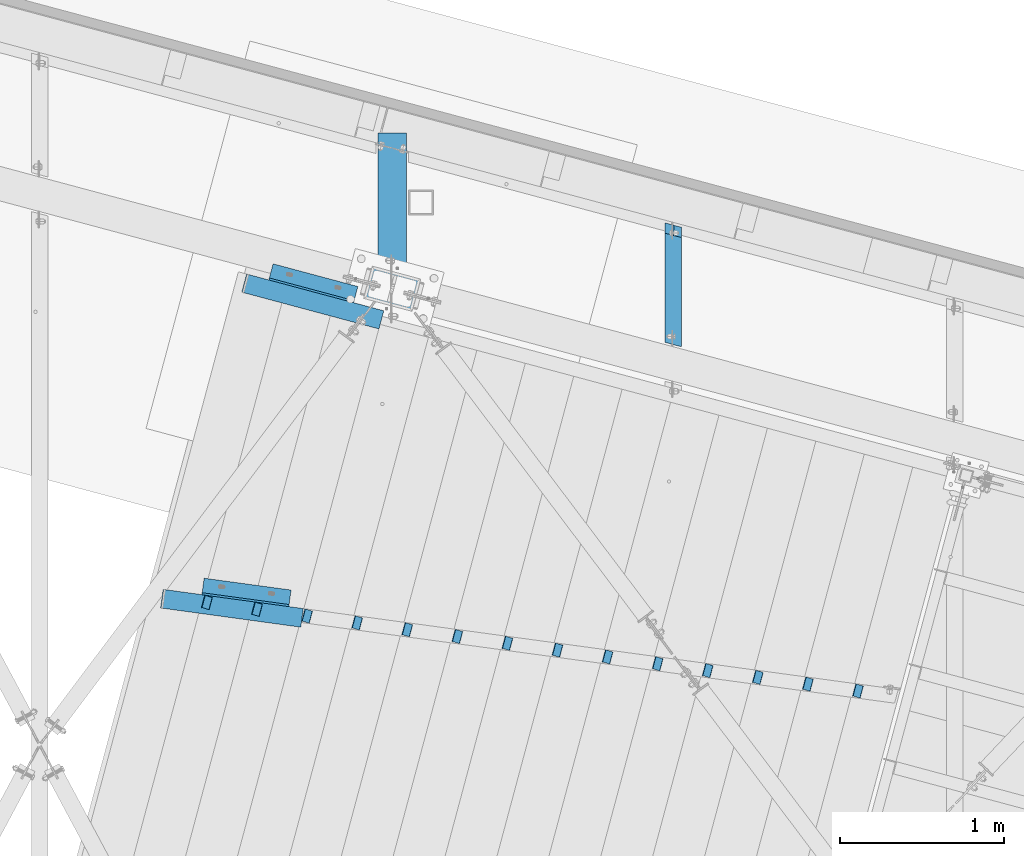
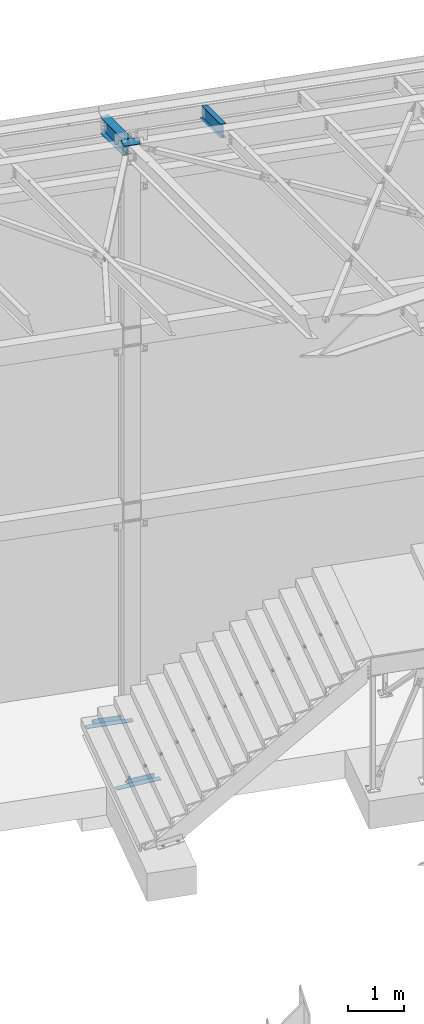
# One storey, part 1383 of 1763: 21 beams, 4 elements without a shape of their own.
"""IFC2X3 building model written with IfcOpenShell, lengths in millimetres."""

from ifc_helpers import new_model, si_unit, frame, origin_with_axes, place, context, subcontext, project, spatial, faceted_brep, material, type_object, element, aggregate, save


model = new_model("IFC2X3")

# Units and contexts
model_context = context("Model", 3, precision=1e-05, world=origin_with_axes())
body_context = subcontext(model_context, "Body", "Model", "MODEL_VIEW")
ifc_project = project(units=[si_unit("LENGTHUNIT", "METRE", prefix="MILLI"), si_unit("AREAUNIT", "SQUARE_METRE"), si_unit("VOLUMEUNIT", "CUBIC_METRE"), si_unit("MASSUNIT", "GRAM", prefix="KILO"), si_unit("TIMEUNIT", "SECOND"), si_unit("PLANEANGLEUNIT", "RADIAN"), si_unit("SOLIDANGLEUNIT", "STERADIAN"), si_unit("THERMODYNAMICTEMPERATUREUNIT", "DEGREE_CELSIUS"), si_unit("LUMINOUSINTENSITYUNIT", "LUMEN")], contexts=[model_context])

# Site, building, storey
site_placement = place(None, origin_with_axes())
site = spatial("IfcSite", under=ifc_project, at=site_placement, CompositionType="ELEMENT")
building_placement = place(site_placement, origin_with_axes())
building = spatial("IfcBuilding", under=site, at=building_placement, Name="Undefined", CompositionType="ELEMENT")
storey_placement = place(building_placement, origin_with_axes())
storey = spatial("IfcBuildingStorey", under=building, at=storey_placement, Name="Undefined", CompositionType="ELEMENT", Elevation=0.0)

# Assembly, beams
assembly_1_placement = place(storey_placement, origin_with_axes())
assembly_1 = element("IfcElementAssembly", 1, at=assembly_1_placement, inside=storey, Name="STRINGER", AssemblyPlace="NOTDEFINED", PredefinedType="RIGID_FRAME")
ifc_material_1 = material(Name="STEEL/A36")
beam_type_1 = type_object("IfcBeamType", PredefinedType="NOTDEFINED")
beam_1_placement = place(assembly_1_placement, frame((-32257.8929743746, 62483.215726575, 193.063692657054), z_axis=(-0.258071073102524, -0.963345292380013, -0.0732473131041585), x_axis=(0.00994755899556624, 0.0731619339676307, -0.997270463559483)))
beam_1 = element("IfcBeam", 2, at=beam_1_placement, type_object=beam_type_1, material=ifc_material_1, Name="BENT_PLATE", context=body_context, shape_type="Brep", body=[
    faceted_brep([(5.39785105502233e-10, -1.58750000003783, -38.1000000000276), (4.97038854518905e-10, -1.58749999996508, 38.1000000000204), (-5.39785105502233e-10, 1.58750000003783, 38.1000000000276), (-4.96129359817132e-10, 1.58749999996508, -38.1000000000204), (44.4500022126981, 1.58750001461158, 38.1000000002023), (44.4500022128991, 1.58750001453882, -38.0999999998457), (49.955484840892, -1.58749998366693, -38.0999999998312), (49.955484840692, -1.58749998358689, 38.1000000002168), (19.0069460021473, 45.5567094321814, 38.1000000001077), (19.0069460021537, 45.5567094321814, -38.0999999999403), (21.7550213319014, 47.1469002955637, 38.100000000115), (21.7550213319087, 47.146900295571, -38.0999999999258)], [[[0, 1, 2, 3]], [[3, 2, 4, 5]], [[1, 0, 6, 7]], [[5, 4, 8, 9]], [[4, 2, 1, 7, 10, 8]], [[7, 6, 11, 10]], [[6, 0, 3, 5, 9, 11]], [[10, 11, 9, 8]]]),
])
beam_2_placement = place(assembly_1_placement, frame((-31953.4268653583, 62441.8346668911, 370.863710967601), z_axis=(-0.258071073102524, -0.963345292380013, -0.0732473131041585), x_axis=(0.00994755899556624, 0.0731619339676307, -0.997270463559483)))
beam_2 = element("IfcBeam", 3, at=beam_2_placement, type_object=beam_type_1, material=ifc_material_1, Name="BENT_PLATE", context=body_context, shape_type="Brep", body=[
    faceted_brep([(5.39785105502233e-10, -1.58750000003783, -38.1000000000276), (4.97038854518905e-10, -1.58749999996508, 38.1000000000204), (-5.39785105502233e-10, 1.58750000003783, 38.1000000000276), (-4.96129359817132e-10, 1.58749999996508, -38.1000000000204), (44.4500022126981, 1.58750001461158, 38.1000000002023), (44.4500022128991, 1.58750001453882, -38.0999999998457), (49.955484840892, -1.58749998366693, -38.0999999998312), (49.955484840692, -1.58749998358689, 38.1000000002168), (19.0069460021473, 45.5567094321814, 38.1000000001077), (19.0069460021537, 45.5567094321814, -38.0999999999403), (21.7550213319014, 47.1469002955637, 38.100000000115), (21.7550213319087, 47.146900295571, -38.0999999999258)], [[[0, 1, 2, 3]], [[3, 2, 4, 5]], [[1, 0, 6, 7]], [[5, 4, 8, 9]], [[4, 2, 1, 7, 10, 8]], [[7, 6, 11, 10]], [[6, 0, 3, 5, 9, 11]], [[10, 11, 9, 8]]]),
])
beam_3_placement = place(assembly_1_placement, frame((-31648.9691036116, 62400.4225529732, 548.66369876057), z_axis=(-0.258071073102524, -0.963345292380013, -0.0732473131041585), x_axis=(0.00994755899556624, 0.0731619339676307, -0.997270463559483)))
beam_3 = element("IfcBeam", 4, at=beam_3_placement, type_object=beam_type_1, material=ifc_material_1, Name="BENT_PLATE", context=body_context, shape_type="Brep", body=[
    faceted_brep([(5.39785105502233e-10, -1.58750000003783, -38.1000000000276), (4.97038854518905e-10, -1.58749999996508, 38.1000000000204), (-5.39785105502233e-10, 1.58750000003783, 38.1000000000276), (-4.96129359817132e-10, 1.58749999996508, -38.1000000000204), (44.4500022126981, 1.58750001461158, 38.1000000002023), (44.4500022128991, 1.58750001453882, -38.0999999998457), (49.955484840892, -1.58749998366693, -38.0999999998312), (49.955484840692, -1.58749998358689, 38.1000000002168), (19.0069460021473, 45.5567094321814, 38.1000000001077), (19.0069460021537, 45.5567094321814, -38.0999999999403), (21.7550213319014, 47.1469002955637, 38.100000000115), (21.7550213319087, 47.146900295571, -38.0999999999258)], [[[0, 1, 2, 3]], [[3, 2, 4, 5]], [[1, 0, 6, 7]], [[5, 4, 8, 9]], [[4, 2, 1, 7, 10, 8]], [[7, 6, 11, 10]], [[6, 0, 3, 5, 9, 11]], [[10, 11, 9, 8]]]),
])
beam_4_placement = place(assembly_1_placement, frame((-31344.501351588, 62359.0477160414, 726.463686553539), z_axis=(-0.258071073102524, -0.963345292380013, -0.0732473131041585), x_axis=(0.00994755899556624, 0.0731619339676307, -0.997270463559483)))
beam_4 = element("IfcBeam", 5, at=beam_4_placement, type_object=beam_type_1, material=ifc_material_1, Name="BENT_PLATE", context=body_context, shape_type="Brep", body=[
    faceted_brep([(5.39785105502233e-10, -1.58750000003783, -38.1000000000276), (4.97038854518905e-10, -1.58749999996508, 38.1000000000204), (-5.39785105502233e-10, 1.58750000003783, 38.1000000000276), (-4.96129359817132e-10, 1.58749999996508, -38.1000000000204), (44.4500022126981, 1.58750001461158, 38.1000000002023), (44.4500022128991, 1.58750001453882, -38.0999999998457), (49.955484840892, -1.58749998366693, -38.0999999998312), (49.955484840692, -1.58749998358689, 38.1000000002168), (19.0069460021473, 45.5567094321814, 38.1000000001077), (19.0069460021537, 45.5567094321814, -38.0999999999403), (21.7550213319014, 47.1469002955637, 38.100000000115), (21.7550213319087, 47.146900295571, -38.0999999999258)], [[[0, 1, 2, 3]], [[3, 2, 4, 5]], [[1, 0, 6, 7]], [[5, 4, 8, 9]], [[4, 2, 1, 7, 10, 8]], [[7, 6, 11, 10]], [[6, 0, 3, 5, 9, 11]], [[10, 11, 9, 8]]]),
])
beam_5_placement = place(assembly_1_placement, frame((-31040.0451977888, 62317.6293746045, 904.263735381664), z_axis=(-0.258071073102524, -0.963345292380013, -0.0732473131041585), x_axis=(0.00994755899556624, 0.0731619339676307, -0.997270463559483)))
beam_5 = element("IfcBeam", 6, at=beam_5_placement, type_object=beam_type_1, material=ifc_material_1, Name="BENT_PLATE", context=body_context, shape_type="Brep", body=[
    faceted_brep([(5.39785105502233e-10, -1.58750000003783, -38.1000000000276), (4.97038854518905e-10, -1.58749999996508, 38.1000000000204), (-5.39785105502233e-10, 1.58750000003783, 38.1000000000276), (-4.96129359817132e-10, 1.58749999996508, -38.1000000000204), (44.4500022126981, 1.58750001461158, 38.1000000002023), (44.4500022128991, 1.58750001453882, -38.0999999998457), (49.955484840892, -1.58749998366693, -38.0999999998312), (49.955484840692, -1.58749998358689, 38.1000000002168), (19.0069460021473, 45.5567094321814, 38.1000000001077), (19.0069460021537, 45.5567094321814, -38.0999999999403), (21.7550213319014, 47.1469002955637, 38.100000000115), (21.7550213319087, 47.146900295571, -38.0999999999258)], [[[0, 1, 2, 3]], [[3, 2, 4, 5]], [[1, 0, 6, 7]], [[5, 4, 8, 9]], [[4, 2, 1, 7, 10, 8]], [[7, 6, 11, 10]], [[6, 0, 3, 5, 9, 11]], [[10, 11, 9, 8]]]),
])
beam_6_placement = place(assembly_1_placement, frame((-30735.5773773245, 62276.254528367, 1082.06366213948), z_axis=(-0.258071073102524, -0.963345292380013, -0.0732473131041585), x_axis=(0.00994755899556624, 0.0731619339676307, -0.997270463559483)))
beam_6 = element("IfcBeam", 7, at=beam_6_placement, type_object=beam_type_1, material=ifc_material_1, Name="BENT_PLATE", context=body_context, shape_type="Brep", body=[
    faceted_brep([(5.39785105502233e-10, -1.58750000003783, -38.1000000000276), (4.97038854518905e-10, -1.58749999996508, 38.1000000000204), (-5.39785105502233e-10, 1.58750000003783, 38.1000000000276), (-4.96129359817132e-10, 1.58749999996508, -38.1000000000204), (44.4500022126981, 1.58750001461158, 38.1000000002023), (44.4500022128991, 1.58750001453882, -38.0999999998457), (49.955484840892, -1.58749998366693, -38.0999999998312), (49.955484840692, -1.58749998358689, 38.1000000002168), (19.0069460021473, 45.5567094321814, 38.1000000001077), (19.0069460021537, 45.5567094321814, -38.0999999999403), (21.7550213319014, 47.1469002955637, 38.100000000115), (21.7550213319087, 47.146900295571, -38.0999999999258)], [[[0, 1, 2, 3]], [[3, 2, 4, 5]], [[1, 0, 6, 7]], [[5, 4, 8, 9]], [[4, 2, 1, 7, 10, 8]], [[7, 6, 11, 10]], [[6, 0, 3, 5, 9, 11]], [[10, 11, 9, 8]]]),
])
beam_7_placement = place(assembly_1_placement, frame((-30431.1155222984, 62234.8579524917, 1259.8637109676), z_axis=(-0.258071073102524, -0.963345292380013, -0.0732473131041585), x_axis=(0.00994755899556624, 0.0731619339676307, -0.997270463559483)))
beam_7 = element("IfcBeam", 8, at=beam_7_placement, type_object=beam_type_1, material=ifc_material_1, Name="BENT_PLATE", context=body_context, shape_type="Brep", body=[
    faceted_brep([(5.39785105502233e-10, -1.58750000003783, -38.1000000000276), (4.97038854518905e-10, -1.58749999996508, 38.1000000000204), (-5.39785105502233e-10, 1.58750000003783, 38.1000000000276), (-4.96129359817132e-10, 1.58749999996508, -38.1000000000204), (44.4500022126981, 1.58750001461158, 38.1000000002023), (44.4500022128991, 1.58750001453882, -38.0999999998457), (49.955484840892, -1.58749998366693, -38.0999999998312), (49.955484840692, -1.58749998358689, 38.1000000002168), (19.0069460021473, 45.5567094321814, 38.1000000001077), (19.0069460021537, 45.5567094321814, -38.0999999999403), (21.7550213319014, 47.1469002955637, 38.100000000115), (21.7550213319087, 47.146900295571, -38.0999999999258)], [[[0, 1, 2, 3]], [[3, 2, 4, 5]], [[1, 0, 6, 7]], [[5, 4, 8, 9]], [[4, 2, 1, 7, 10, 8]], [[7, 6, 11, 10]], [[6, 0, 3, 5, 9, 11]], [[10, 11, 9, 8]]]),
])
beam_8_placement = place(assembly_1_placement, frame((-30126.6593668389, 62193.4396108291, 1437.66363772541), z_axis=(-0.258071073102524, -0.963345292380013, -0.0732473131041585), x_axis=(0.00994755899556624, 0.0731619339676307, -0.997270463559483)))
beam_8 = element("IfcBeam", 9, at=beam_8_placement, type_object=beam_type_1, material=ifc_material_1, Name="BENT_PLATE", context=body_context, shape_type="Brep", body=[
    faceted_brep([(5.39785105502233e-10, -1.58750000003783, -38.1000000000276), (4.97038854518905e-10, -1.58749999996508, 38.1000000000204), (-5.39785105502233e-10, 1.58750000003783, 38.1000000000276), (-4.96129359817132e-10, 1.58749999996508, -38.1000000000204), (44.4500022126981, 1.58750001461158, 38.1000000002023), (44.4500022128991, 1.58750001453882, -38.0999999998457), (49.955484840892, -1.58749998366693, -38.0999999998312), (49.955484840692, -1.58749998358689, 38.1000000002168), (19.0069460021473, 45.5567094321814, 38.1000000001077), (19.0069460021537, 45.5567094321814, -38.0999999999403), (21.7550213319014, 47.1469002955637, 38.100000000115), (21.7550213319087, 47.146900295571, -38.0999999999258)], [[[0, 1, 2, 3]], [[3, 2, 4, 5]], [[1, 0, 6, 7]], [[5, 4, 8, 9]], [[4, 2, 1, 7, 10, 8]], [[7, 6, 11, 10]], [[6, 0, 3, 5, 9, 11]], [[10, 11, 9, 8]]]),
])
beam_9_placement = place(assembly_1_placement, frame((-29822.1915519805, 62152.0647653538, 1615.46368655354), z_axis=(-0.258071073102524, -0.963345292380013, -0.0732473131041585), x_axis=(0.00994755899556624, 0.0731619339676307, -0.997270463559483)))
beam_9 = element("IfcBeam", 10, at=beam_9_placement, type_object=beam_type_1, material=ifc_material_1, Name="BENT_PLATE", context=body_context, shape_type="Brep", body=[
    faceted_brep([(5.39785105502233e-10, -1.58750000003783, -38.1000000000276), (4.97038854518905e-10, -1.58749999996508, 38.1000000000204), (-5.39785105502233e-10, 1.58750000003783, 38.1000000000276), (-4.96129359817132e-10, 1.58749999996508, -38.1000000000204), (44.4500022126981, 1.58750001461158, 38.1000000002023), (44.4500022128991, 1.58750001453882, -38.0999999998457), (49.955484840892, -1.58749998366693, -38.0999999998312), (49.955484840692, -1.58749998358689, 38.1000000002168), (19.0069460021473, 45.5567094321814, 38.1000000001077), (19.0069460021537, 45.5567094321814, -38.0999999999403), (21.7550213319014, 47.1469002955637, 38.100000000115), (21.7550213319087, 47.146900295571, -38.0999999999258)], [[[0, 1, 2, 3]], [[3, 2, 4, 5]], [[1, 0, 6, 7]], [[5, 4, 8, 9]], [[4, 2, 1, 7, 10, 8]], [[7, 6, 11, 10]], [[6, 0, 3, 5, 9, 11]], [[10, 11, 9, 8]]]),
])
beam_10_placement = place(assembly_1_placement, frame((-29517.7295712845, 62110.6681723917, 1793.26373538166), z_axis=(-0.258071073102524, -0.963345292380013, -0.0732473131041585), x_axis=(0.00994755899556624, 0.0731619339676307, -0.997270463559483)))
beam_10 = element("IfcBeam", 11, at=beam_10_placement, type_object=beam_type_1, material=ifc_material_1, Name="BENT_PLATE", context=body_context, shape_type="Brep", body=[
    faceted_brep([(5.39785105502233e-10, -1.58750000003783, -38.1000000000276), (4.97038854518905e-10, -1.58749999996508, 38.1000000000204), (-5.39785105502233e-10, 1.58750000003783, 38.1000000000276), (-4.96129359817132e-10, 1.58749999996508, -38.1000000000204), (44.4500022126981, 1.58750001461158, 38.1000000002023), (44.4500022128991, 1.58750001453882, -38.0999999998457), (49.955484840892, -1.58749998366693, -38.0999999998312), (49.955484840692, -1.58749998358689, 38.1000000002168), (19.0069460021473, 45.5567094321814, 38.1000000001077), (19.0069460021537, 45.5567094321814, -38.0999999999403), (21.7550213319014, 47.1469002955637, 38.100000000115), (21.7550213319087, 47.146900295571, -38.0999999999258)], [[[0, 1, 2, 3]], [[3, 2, 4, 5]], [[1, 0, 6, 7]], [[5, 4, 8, 9]], [[4, 2, 1, 7, 10, 8]], [[7, 6, 11, 10]], [[6, 0, 3, 5, 9, 11]], [[10, 11, 9, 8]]]),
])
beam_11_placement = place(assembly_1_placement, frame((-29213.273407934, 62069.2498296561, 1971.06378420979), z_axis=(-0.258071073102524, -0.963345292380013, -0.0732473131041585), x_axis=(0.00994755899556624, 0.0731619339676307, -0.997270463559483)))
beam_11 = element("IfcBeam", 12, at=beam_11_placement, type_object=beam_type_1, material=ifc_material_1, Name="BENT_PLATE", context=body_context, shape_type="Brep", body=[
    faceted_brep([(5.39785105502233e-10, -1.58750000003783, -38.1000000000276), (4.97038854518905e-10, -1.58749999996508, 38.1000000000204), (-5.39785105502233e-10, 1.58750000003783, 38.1000000000276), (-4.96129359817132e-10, 1.58749999996508, -38.1000000000204), (44.4500022126981, 1.58750001461158, 38.1000000002023), (44.4500022128991, 1.58750001453882, -38.0999999998457), (49.955484840892, -1.58749998366693, -38.0999999998312), (49.955484840692, -1.58749998358689, 38.1000000002168), (19.0069460021473, 45.5567094321814, 38.1000000001077), (19.0069460021537, 45.5567094321814, -38.0999999999403), (21.7550213319014, 47.1469002955637, 38.100000000115), (21.7550213319087, 47.146900295571, -38.0999999999258)], [[[0, 1, 2, 3]], [[3, 2, 4, 5]], [[1, 0, 6, 7]], [[5, 4, 8, 9]], [[4, 2, 1, 7, 10, 8]], [[7, 6, 11, 10]], [[6, 0, 3, 5, 9, 11]], [[10, 11, 9, 8]]]),
])
beam_12_placement = place(assembly_1_placement, frame((-28908.8058286325, 62027.8750162086, 2148.86358889729), z_axis=(-0.258071073102524, -0.963345292380013, -0.0732473131041585), x_axis=(0.00994755899556624, 0.0731619339676307, -0.997270463559483)))
beam_12 = element("IfcBeam", 13, at=beam_12_placement, type_object=beam_type_1, material=ifc_material_1, Name="BENT_PLATE", context=body_context, shape_type="Brep", body=[
    faceted_brep([(5.39785105502233e-10, -1.58750000003783, -38.1000000000276), (4.97038854518905e-10, -1.58749999996508, 38.1000000000204), (-5.39785105502233e-10, 1.58750000003783, 38.1000000000276), (-4.96129359817132e-10, 1.58749999996508, -38.1000000000204), (44.4500022126981, 1.58750001461158, 38.1000000002023), (44.4500022128991, 1.58750001453882, -38.0999999998457), (49.955484840892, -1.58749998366693, -38.0999999998312), (49.955484840692, -1.58749998358689, 38.1000000002168), (19.0069460021473, 45.5567094321814, 38.1000000001077), (19.0069460021537, 45.5567094321814, -38.0999999999403), (21.7550213319014, 47.1469002955637, 38.100000000115), (21.7550213319087, 47.146900295571, -38.0999999999258)], [[[0, 1, 2, 3]], [[3, 2, 4, 5]], [[1, 0, 6, 7]], [[5, 4, 8, 9]], [[4, 2, 1, 7, 10, 8]], [[7, 6, 11, 10]], [[6, 0, 3, 5, 9, 11]], [[10, 11, 9, 8]]]),
])
beam_13_placement = place(assembly_1_placement, frame((-28604.3398113067, 61986.4778744005, 2326.66363772541), z_axis=(-0.258071073102524, -0.963345292380013, -0.0732473131041585), x_axis=(0.00994755899556624, 0.0731619339676307, -0.997270463559483)))
beam_13 = element("IfcBeam", 14, at=beam_13_placement, type_object=beam_type_1, material=ifc_material_1, Name="BENT_PLATE", context=body_context, shape_type="Brep", body=[
    faceted_brep([(5.39785105502233e-10, -1.58750000003783, -38.1000000000276), (4.97038854518905e-10, -1.58749999996508, 38.1000000000204), (-5.39785105502233e-10, 1.58750000003783, 38.1000000000276), (-4.96129359817132e-10, 1.58749999996508, -38.1000000000204), (44.4500022126981, 1.58750001461158, 38.1000000002023), (44.4500022128991, 1.58750001453882, -38.0999999998457), (49.955484840892, -1.58749998366693, -38.0999999998312), (49.955484840692, -1.58749998358689, 38.1000000002168), (19.0069460021473, 45.5567094321814, 38.1000000001077), (19.0069460021537, 45.5567094321814, -38.0999999999403), (21.7550213319014, 47.1469002955637, 38.100000000115), (21.7550213319087, 47.146900295571, -38.0999999999258)], [[[0, 1, 2, 3]], [[3, 2, 4, 5]], [[1, 0, 6, 7]], [[5, 4, 8, 9]], [[4, 2, 1, 7, 10, 8]], [[7, 6, 11, 10]], [[6, 0, 3, 5, 9, 11]], [[10, 11, 9, 8]]]),
])
beam_14_placement = place(assembly_1_placement, frame((-28299.8818615935, 61945.0818297477, 2504.46368655354), z_axis=(-0.258071073102524, -0.963345292380013, -0.0732473131041585), x_axis=(0.00994755899556624, 0.0731619339676307, -0.997270463559483)))
beam_14 = element("IfcBeam", 15, at=beam_14_placement, type_object=beam_type_1, material=ifc_material_1, Name="BENT_PLATE", context=body_context, shape_type="Brep", body=[
    faceted_brep([(5.39785105502233e-10, -1.58750000003783, -38.1000000000276), (4.97038854518905e-10, -1.58749999996508, 38.1000000000204), (-5.39785105502233e-10, 1.58750000003783, 38.1000000000276), (-4.96129359817132e-10, 1.58749999996508, -38.1000000000204), (44.4500022126981, 1.58750001461158, 38.1000000002023), (44.4500022128991, 1.58750001453882, -38.0999999998457), (49.955484840892, -1.58749998366693, -38.0999999998312), (49.955484840692, -1.58749998358689, 38.1000000002168), (19.0069460021473, 45.5567094321814, 38.1000000001077), (19.0069460021537, 45.5567094321814, -38.0999999999403), (21.7550213319014, 47.1469002955637, 38.100000000115), (21.7550213319087, 47.146900295571, -38.0999999999258)], [[[0, 1, 2, 3]], [[3, 2, 4, 5]], [[1, 0, 6, 7]], [[5, 4, 8, 9]], [[4, 2, 1, 7, 10, 8]], [[7, 6, 11, 10]], [[6, 0, 3, 5, 9, 11]], [[10, 11, 9, 8]]]),
])

# Assembly, beam
assembly_2_placement = place(storey_placement, origin_with_axes())
assembly_2 = element("IfcElementAssembly", 16, at=assembly_2_placement, inside=storey, Name="BEAM", AssemblyPlace="NOTDEFINED", PredefinedType="RIGID_FRAME")
ifc_material_2 = material(Name="STEEL/A992")
beam_type_2 = type_object("IfcBeamType", Name="W14X30", PredefinedType="NOTDEFINED")
beam_15_placement = place(assembly_2_placement, frame((-31109.3096174484, 64387.8110729685, 12269.7875), z_axis=(0.0, 0.0, 1.0), x_axis=(0.0, 1.0, 0.0)))
beam_15 = element("IfcBeam", 17, at=beam_15_placement, type_object=beam_type_2, material=ifc_material_2, Name="BEAM", ObjectType="W14X30", context=body_context, shape_type="Brep", body=[
    faceted_brep([(121.590793634008, 3.17499999999927, -166.6875), (119.888986031343, -3.17499999999927, -166.6875), (139.611254192037, -3.17499999999927, -166.6875), (141.313061794594, 3.17499999999927, -166.6875), (155.637009837992, -3.17499999999927, -155.679724376636), (157.338817440548, 3.17499999999927, -155.679724378537), (158.994527176001, -3.17499999999927, -152.226204475199), (160.696334778557, 3.17499999999927, -152.2262044771), (152.054955248466, 3.17499999999927, -138.112500961954), (150.353147645903, -3.17499999999927, -138.112500960051), (117.482719988795, -3.17499999999927, -138.112500048835), (119.184527591358, 3.17499999999927, -138.112500050745), (157.338817007636, 3.17499999999927, -139.595277471493), (155.637009405073, -3.17499999999927, -139.595277469592), (160.696334531545, 3.17499999999927, -143.04879720479), (158.994526928982, -3.17499999999927, -143.048797202888), (161.916090919542, 3.17499999999927, -147.637500810402), (160.214283316978, -3.17499999999927, -147.637500808501), (945.82023175127, 85.7249999999985, 176.2125), (945.82023175127, 85.7249999999985, 166.6875), (163.436559781578, 85.7249999999985, 166.6875), (138.020964066513, 85.7249999999985, 166.6875), (143.714292389333, 85.7249999999985, 176.212500751237), (945.82023175127, -85.7249999999985, 176.2125), (97.7654871174091, -85.7249999999985, 176.2125), (117.487754512411, -85.7249999999985, 166.6875), (945.82023175127, -85.7249999999985, 166.6875), (92.0721587945882, -85.7249999999985, 166.6875), (139.611253345713, -3.17499999999927, 166.6875), (945.82023175127, -3.17499999999927, 166.6875), (114.195657629214, -3.17499999999927, 166.6875), (945.82023175127, -85.7249999999985, -176.2125), (945.82023175127, -85.7249999999985, -166.6875), (117.487755358728, -85.7249999999985, -166.6875), (97.765487196717, -85.7249999999985, -166.6875), (92.072158876319, -85.7249999999985, -176.2125), (945.82023175127, 85.7249999999985, -176.2125), (138.020964145602, 85.7249999999985, -176.2125), (163.436560627903, 85.7249999999985, -166.687499479031), (945.82023175127, 85.7249999999985, -166.6875), (143.714292468641, 85.7249999999985, -166.687499465897), (945.82023175127, 3.17499999999927, -166.6875), (945.82023175127, 3.17499999999927, 166.6875), (945.82023175127, -3.17499999999927, -166.6875), (141.313060948276, 3.17499999999927, 166.6875), (115.897465231879, 3.17499999999927, 166.6875), (157.338816594231, 3.17499999999927, 155.679724294811), (155.637008991667, -3.17499999999927, 155.67972429291), (160.696333932239, 3.17499999999927, 152.226204393373), (158.994526329676, -3.17499999999927, 152.226204391472), (161.916090073217, 3.17499999999927, 147.637500726676), (160.214282470653, -3.17499999999927, 147.637500724775), (160.696333685228, 3.17499999999927, 143.048797121064), (158.994526082664, -3.17499999999927, 143.048797119161), (157.338816161311, 3.17499999999927, 139.595277387767), (155.637008558748, -3.17499999999927, 139.595277385866), (152.054954402149, 3.17499999999927, 138.112500878227), (150.353146799585, -3.17499999999927, 138.112500876325), (119.184509833947, 3.17499999999927, 138.112499949188), (117.482702231384, -3.17499999999927, 138.112499965431)], [[[0, 1, 2, 3]], [[3, 2, 4, 5]], [[5, 4, 6, 7]], [[8, 9, 10, 11]], [[12, 13, 9, 8]], [[14, 15, 13, 12]], [[16, 17, 15, 14]], [[7, 6, 17, 16]], [[18, 19, 20, 21, 22]], [[23, 18, 22, 24]], [[25, 26, 23, 24, 27]], [[28, 29, 26, 25, 27, 30]], [[31, 32, 33, 34, 35]], [[36, 31, 35, 37]], [[38, 39, 36, 37, 40]], [[41, 42, 19, 18, 23, 26, 29, 43, 32, 31, 36, 39]], [[20, 19, 42, 44, 45, 21]], [[27, 24, 22, 21, 45, 30]], [[44, 28, 30, 45]], [[46, 47, 28, 44]], [[48, 49, 47, 46]], [[50, 51, 49, 48]], [[52, 53, 51, 50]], [[54, 55, 53, 52]], [[56, 57, 55, 54]], [[57, 56, 58, 59]], [[59, 58, 11, 10]], [[4, 2, 43, 29, 28, 47, 49, 51, 53, 55, 57, 59, 10, 9, 13, 15, 17, 6]], [[33, 32, 43, 2, 1, 34]], [[40, 37, 35, 34, 1, 0]], [[3, 41, 39, 38, 40, 0]], [[12, 8, 11, 58, 56, 54, 52, 50, 48, 46, 44, 42, 41, 3, 5, 7, 16, 14]]]),
])
aggregate(assembly_2, [beam_15])

# Beam
beam_type_3 = type_object("IfcBeamType", PredefinedType="NOTDEFINED")
beam_16_placement = place(assembly_1_placement, frame((-31175.0605583765, 64197.7042297084, 4.7625030517378), z_axis=(-0.25881614695716, -0.965926602840117, 0.0), x_axis=(-0.965926602840118, 0.258816146957159, 0.0)))
beam_16 = element("IfcBeam", 18, at=beam_16_placement, type_object=beam_type_3, material=ifc_material_1, Name="PLATE", context=body_context, shape_type="Brep", body=[
    faceted_brep([(0.0, 4.76249999989523, -57.1500000001702), (0.0, 4.76250000014261, 57.1500000001565), (863.662671589191, 4.7625, 57.1500000024971), (863.662671589125, 4.7625, -57.1499999974258), (0.0, -4.76249999988067, 57.1500000001784), (863.662671589191, -4.7625, 57.1500000024971), (0.0, -4.76250000012806, -57.150000000152), (863.662671589125, -4.7625, -57.1499999974258)], [[[0, 1, 2, 3]], [[1, 4, 5, 2]], [[4, 6, 7, 5]], [[6, 0, 3, 7]], [[5, 7, 3, 2]], [[6, 4, 1, 0]]]),
])

beam_17_placement = place(assembly_1_placement, frame((-31657.4570207808, 62385.8898300157, 4.82399550916217), z_axis=(-0.135871520576319, -0.990726464429881, -5.07399999836135e-05), x_axis=(-0.990726462533892, 0.135871524073218, -7.33560000395305e-05)))
beam_17 = element("IfcBeam", 19, at=beam_17_placement, type_object=beam_type_3, material=ifc_material_1, Name="PLATE", context=body_context, shape_type="Brep", body=[
    faceted_brep([(0.0, 4.76249999989523, -57.1500000001702), (0.0, 4.76250000014261, 57.1500000001565), (860.167691025774, 4.76250000000015, 57.1500000013984), (860.167691025883, 4.76250000000011, -57.1499999983644), (0.0, -4.76249999988067, 57.1500000001784), (860.167691025774, -4.76249999999985, 57.1500000013912), (0.0, -4.76250000012806, -57.150000000152), (860.167691025868, -4.76249999999989, -57.1499999983789)], [[[0, 1, 2, 3]], [[1, 4, 5, 2]], [[4, 6, 7, 5]], [[6, 0, 3, 7]], [[5, 7, 3, 2]], [[6, 4, 1, 0]]]),
])

beam_type_4 = type_object("IfcBeamType", Name="L4X4X1/2", PredefinedType="NOTDEFINED")
beam_18_placement = place(assembly_1_placement, frame((-31846.3405971998, 64489.3676007092, 50.8000030517378), z_axis=(0.25886591203079, 0.965913267114842, 0.0), x_axis=(0.965913267114843, -0.258865912030785, 0.0)))
beam_18 = element("IfcBeam", 20, at=beam_18_placement, type_object=beam_type_4, material=ifc_material_1, Name="ANGLE", ObjectType="L4X4X1/2", context=body_context, shape_type="Brep", body=[
    faceted_brep([(-3.63797880709171e-11, 50.8000000000011, -50.8000000000538), (-1.96450855582952e-10, 50.8000000000393, 50.7999999999374), (533.400000003639, 50.8, 50.8000000003376), (533.400000003698, 50.8, -50.7999999996537), (1.45519152283669e-10, 38.0999999999985, 50.7999999999993), (533.400000003639, 38.1, 50.8000000003376), (0.0, 38.0999999999985, -38.1000000000004), (533.40000000369, 38.1, -38.0999999996566), (2.18278728425503e-11, -50.8, -38.099999999984), (533.40000000369, -50.8, -38.0999999996566), (2.11002770811319e-10, -50.8000000000357, -50.799999999952), (533.400000003698, -50.8, -50.7999999996537)], [[[0, 1, 2, 3]], [[1, 4, 5, 2]], [[4, 6, 7, 5]], [[6, 8, 9, 7]], [[8, 10, 11, 9]], [[10, 0, 3, 11]], [[5, 7, 9, 11, 3, 2]], [[10, 8, 6, 4, 1, 0]]]),
])

beam_19_placement = place(assembly_1_placement, frame((-32259.3966334868, 62576.655832826, 50.7178447643528), z_axis=(0.134697651054261, 0.990886744399135, 5.07400000204432e-05), x_axis=(0.990886669908159, -0.134697619987516, -0.000398205999963087)))
beam_19 = element("IfcBeam", 21, at=beam_19_placement, type_object=beam_type_4, material=ifc_material_1, Name="ANGLE", ObjectType="L4X4X1/2", context=body_context, shape_type="Brep", body=[
    faceted_brep([(-3.63797880709171e-11, 50.8000000000011, -50.8000000000538), (-1.96450855582952e-10, 50.8000000000393, 50.7999999999374), (533.400000003639, 50.8, 50.8000000003376), (533.400000003698, 50.8, -50.7999999996537), (1.45519152283669e-10, 38.0999999999985, 50.7999999999993), (533.400000003639, 38.1, 50.8000000003376), (0.0, 38.0999999999985, -38.1000000000004), (533.40000000369, 38.1, -38.0999999996566), (2.18278728425503e-11, -50.8, -38.099999999984), (533.40000000369, -50.8, -38.0999999996566), (2.11002770811319e-10, -50.8000000000357, -50.799999999952), (533.400000003698, -50.8, -50.7999999996537)], [[[0, 1, 2, 3]], [[1, 4, 5, 2]], [[4, 6, 7, 5]], [[6, 8, 9, 7]], [[8, 10, 11, 9]], [[10, 0, 3, 11]], [[5, 7, 9, 11, 3, 2]], [[10, 8, 6, 4, 1, 0]]]),
])

aggregate(assembly_1, [beam_1, beam_2, beam_3, beam_4, beam_5, beam_6, beam_7, beam_8, beam_9, beam_10, beam_11, beam_12, beam_13, beam_14, beam_18, beam_19, beam_16, beam_17])

# Assembly, beam
assembly_3_placement = place(storey_placement, origin_with_axes())
assembly_3 = element("IfcElementAssembly", 22, at=assembly_3_placement, inside=storey, Name="COLUMN", AssemblyPlace="NOTDEFINED", PredefinedType="RIGID_FRAME")
ifc_material_3 = material(Name="STEEL/A572-50")
beam_type_5 = type_object("IfcBeamType", PredefinedType="NOTDEFINED")
beam_20_placement = place(assembly_3_placement, frame((-30962.1044355401, 64347.5078295432, 12438.0625), z_axis=(0.25886591203079, 0.965913267114842, 0.0), x_axis=(-0.965913267114846, 0.258865912030774, 0.0)))
beam_20 = element("IfcBeam", 23, at=beam_20_placement, type_object=beam_type_5, material=ifc_material_3, Name="PLATE", context=body_context, shape_type="Brep", body=[
    faceted_brep([(-5.82076609134674e-11, 7.9375, -101.599999999991), (0.0, 7.9375, 101.599998474121), (304.799999999937, 7.9375, 101.599999999809), (304.799999999814, 7.9375, -101.60000000018), (0.0, -7.9375, 101.599998474121), (304.799999999937, -7.9375, 101.599999999809), (-5.82076609134674e-11, -7.9375, -101.599999999991), (304.799999999814, -7.9375, -101.60000000018)], [[[0, 1, 2, 3]], [[1, 4, 5, 2]], [[4, 6, 7, 5]], [[6, 0, 3, 7]], [[5, 7, 3, 2]], [[6, 4, 1, 0]]]),
])
aggregate(assembly_3, [beam_20])

assembly_4_placement = place(storey_placement, origin_with_axes())
assembly_4 = element("IfcElementAssembly", 24, at=assembly_4_placement, inside=storey, Name="BEAM", AssemblyPlace="NOTDEFINED", PredefinedType="RIGID_FRAME")
beam_type_6 = type_object("IfcBeamType", Name="W12X16", PredefinedType="NOTDEFINED")
beam_21_placement = place(assembly_4_placement, frame((-29400.5296174484, 63929.0927735385, 12293.6), z_axis=(0.0, 0.0, 1.0), x_axis=(0.0, 1.0, 0.0)))
beam_21 = element("IfcBeam", 25, at=beam_21_placement, type_object=beam_type_6, material=ifc_material_2, Name="BEAM", ObjectType="W12X16", context=body_context, shape_type="Brep", body=[
    faceted_brep([(117.481328757029, -3.17499999999927, -146.049999999999), (104.720248468737, -50.7999999999993, -146.049999999999), (831.242304197956, -50.7999999999993, -146.049999999999), (844.003384486256, -3.17499999999927, -146.049999999999), (104.720248468737, -50.7999999999993, -152.4), (831.242304197956, -50.7999999999993, -152.4), (131.943886417102, 50.7999999999993, -152.4), (858.465942146322, 50.7999999999993, -152.4), (131.943886417102, 50.7999999999993, -146.049999999999), (119.182806128803, 3.17499999999927, -146.049999999999), (845.704861858023, 3.17499999999927, -146.049999999999), (858.465942146322, 50.7999999999993, -146.049999999999), (845.704861858023, 3.17499999999927, 114.299999999999), (844.003384486256, -3.17499999999927, 114.299999999999), (117.481328757029, -3.17499999999927, 146.049999999999), (104.720248468737, -50.7999999999993, 146.049999999999), (104.720248468737, -50.7999999999993, 152.4), (131.943886417102, 50.7999999999993, 152.4), (131.943886417102, 50.7999999999993, 146.049999999999), (119.182806128803, 3.17499999999927, 146.049999999999), (783.25182938738, 3.17499999999927, 146.049999999999), (783.251829387205, 3.17499999999927, 126.999999809264), (784.252661848943, 3.17499999999927, 122.139920291218), (787.102791564437, 3.17499999999927, 118.019743823064), (791.368312120983, 3.17499999999927, 115.266729922587), (796.399836680896, 3.17499999999927, 114.299999999999), (781.550352015445, -3.17499999999927, 126.999999809264), (782.551184477183, -3.17499999999927, 122.139920291218), (785.401314192677, -3.17499999999927, 118.019743823064), (789.666834749223, -3.17499999999927, 115.266729922587), (794.698359309135, -3.17499999999927, 114.299999999999), (781.550352015598, -3.17499999999927, 146.049999999999), (768.78927172727, -50.7999999999993, 146.049999999999), (768.78927172727, -50.7999999999993, 152.4), (796.012909675708, 50.7999999999993, 152.4), (796.012909675708, 50.7999999999993, 146.049999999999)], [[[0, 1, 2, 3]], [[1, 4, 5, 2]], [[4, 6, 7, 5]], [[8, 9, 10, 11]], [[3, 2, 5, 7, 11, 10, 12, 13]], [[6, 8, 11, 7]], [[4, 1, 0, 14, 15, 16, 17, 18, 19, 9, 8, 6]], [[10, 9, 19, 20, 21, 22, 23, 24, 25, 12]], [[21, 26, 27, 22]], [[22, 27, 28, 23]], [[23, 28, 29, 24]], [[24, 29, 30, 25]], [[12, 25, 30, 13]], [[29, 28, 27, 26, 31, 14, 0, 3, 13, 30]], [[15, 14, 31, 32]], [[16, 15, 32, 33]], [[17, 16, 33, 34]], [[18, 17, 34, 35]], [[19, 18, 35, 20]], [[34, 33, 32, 31, 26, 21, 20, 35]]]),
])
aggregate(assembly_4, [beam_21])

save(model, "model.ifc")
